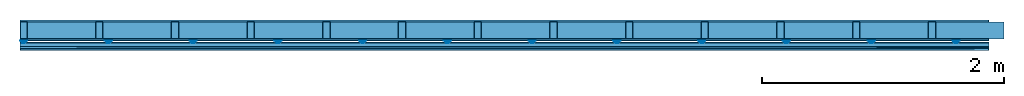
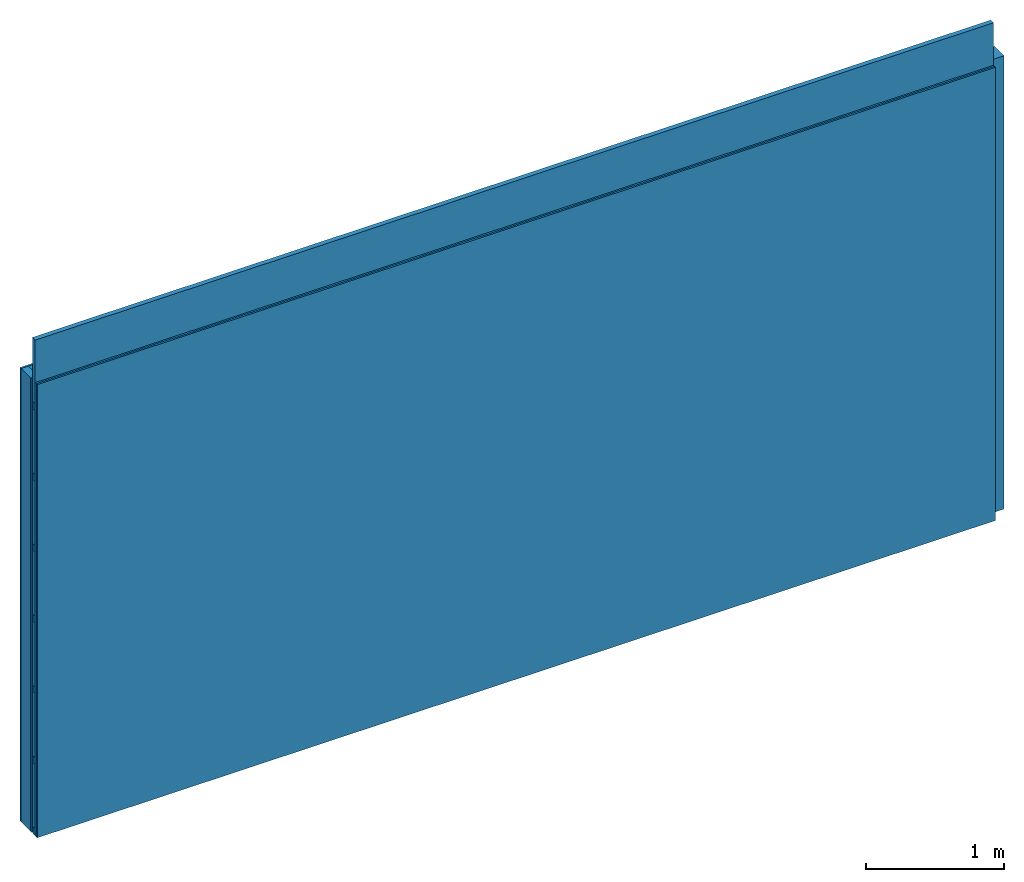
# One storey: 5 members, 4 plates, 1 element without a shape of its own.
"""IFC4 building model written with IfcOpenShell, lengths in metres."""

from ifc_helpers import new_model, si_unit, derived_unit, direction, frame, frame_2d, origin, origin_with_axes, place, context, project, spatial, polyline, rectangle, outline, extrude, material, layer, layer_set, type_object, element, aggregate, save


model = new_model("IFC4")

# Units and contexts
plan_context = context("Plan", 3, precision=1e-05, world=origin(), true_north=direction((0.0, 1.0)))
model_context = context("Model", 3, precision=1e-05, world=origin(), true_north=direction((0.0, 1.0)))
ifc_project = project(units=[si_unit("LENGTHUNIT", "METRE"), derived_unit("SOUNDPRESSUREUNIT", [(si_unit("PRESSUREUNIT", "PASCAL", prefix="MICRO"), 0)]), si_unit("ENERGYUNIT", "JOULE", prefix="MEGA"), si_unit("MASSUNIT", "GRAM", prefix="KILO"), derived_unit("THERMALTRANSMITTANCEUNIT", [(si_unit("POWERUNIT", "WATT"), 1), (si_unit("AREAUNIT", "SQUARE_METRE"), -1), (si_unit("THERMODYNAMICTEMPERATUREUNIT", "KELVIN"), -1)]), derived_unit("AREADENSITYUNIT", [(si_unit("MASSUNIT", "GRAM", prefix="KILO"), 1), (si_unit("AREAUNIT", "SQUARE_METRE"), -1)]), derived_unit("USERDEFINED", [(si_unit("ENERGYUNIT", "JOULE", prefix="MEGA"), 1), (si_unit("AREAUNIT", "SQUARE_METRE"), -1)])], contexts=[plan_context, model_context])

# Site, building, storey
site = spatial("IfcSite", under=ifc_project)
building_placement = place(None, origin())
building = spatial("IfcBuilding", under=site, at=building_placement)
storey_placement = place(building_placement, origin())
storey = spatial("IfcBuildingStorey", under=building, at=storey_placement)

# Wall, members, plates
ifc_material_1 = material(Name="Glued joints")
ifc_layer_1 = layer(ifc_material_1, 0.0, Name="Surface")
ifc_material_2 = material(Category="03.007")
ifc_layer_2 = layer(ifc_material_2, 0.015, Name="1st layer")
ifc_material_3 = material(Name="of the art")
ifc_layer_3 = layer(ifc_material_3, 0.0, Name="Bond")
ifc_layer_4 = layer(None, 0.14, Name="Support")
ifc_layer_5 = layer(ifc_material_3, 0.0, Name="Bond")
ifc_layer_6 = layer(ifc_material_2, 0.015, Name="1st layer")
ifc_layer_7 = layer(None, 0.02, Name="Coupling")
ifc_layer_8 = layer(None, 0.03, Name="Battens / profiles")
ifc_layer_9 = layer(ifc_material_2, 0.015, Name="Covering 1st layer")
ifc_layer_10 = layer(ifc_material_2, 0.015, Name="Covering 2nd layer")
ifc_layer_11 = layer(ifc_material_1, 0.0, Name="Surface")
ifc_layer_set = layer_set([ifc_layer_1, ifc_layer_2, ifc_layer_3, ifc_layer_4, ifc_layer_5, ifc_layer_6, ifc_layer_7, ifc_layer_8, ifc_layer_9, ifc_layer_10, ifc_layer_11])
wall_type = type_object("IfcWallType", Name="C0080", PredefinedType="NOTDEFINED", material=ifc_layer_set)
wall_placement = place(None, frame((0.0, 0.0, 0.0), z_axis=(0.0, -1.0, 0.0), x_axis=(1.0, 0.0, 0.0)))
wall = element("IfcWall", 1, at=wall_placement, inside=storey, type_object=wall_type, material=ifc_layer_set, Name="Wall #1")
ifc_material_4 = material()
member_1_placement = place(wall_placement, origin())
member_1 = element("IfcMember", 2, at=member_1_placement, material=ifc_material_4, Name="Support", context=plan_context, shape_type="SweptSolid", body=[
    extrude(rectangle(XDim=0.06, YDim=0.14, at=frame_2d((0.03, 0.07), x_axis=(1.0, 0.0))), frame((0.0, 4.0, 0.015), z_axis=(0.0, -1.0, 0.0), x_axis=(1.0, 0.0, 0.0)), (0.0, 0.0, 1.0), 4.0),
    extrude(rectangle(XDim=0.06, YDim=0.14, at=frame_2d((0.03, 0.07), x_axis=(1.0, 0.0))), frame((0.625, 4.0, 0.015), z_axis=(0.0, -1.0, 0.0), x_axis=(1.0, 0.0, 0.0)), (0.0, 0.0, 1.0), 4.0),
    extrude(rectangle(XDim=0.06, YDim=0.14, at=frame_2d((0.03, 0.07), x_axis=(1.0, 0.0))), frame((1.25, 4.0, 0.015), z_axis=(0.0, -1.0, 0.0), x_axis=(1.0, 0.0, 0.0)), (0.0, 0.0, 1.0), 4.0),
    extrude(rectangle(XDim=0.06, YDim=0.14, at=frame_2d((0.03, 0.07), x_axis=(1.0, 0.0))), frame((1.875, 4.0, 0.015), z_axis=(0.0, -1.0, 0.0), x_axis=(1.0, 0.0, 0.0)), (0.0, 0.0, 1.0), 4.0),
    extrude(rectangle(XDim=0.06, YDim=0.14, at=frame_2d((0.03, 0.07), x_axis=(1.0, 0.0))), frame((2.5, 4.0, 0.015), z_axis=(0.0, -1.0, 0.0), x_axis=(1.0, 0.0, 0.0)), (0.0, 0.0, 1.0), 4.0),
    extrude(rectangle(XDim=0.06, YDim=0.14, at=frame_2d((0.03, 0.07), x_axis=(1.0, 0.0))), frame((3.125, 4.0, 0.015), z_axis=(0.0, -1.0, 0.0), x_axis=(1.0, 0.0, 0.0)), (0.0, 0.0, 1.0), 4.0),
    extrude(rectangle(XDim=0.06, YDim=0.14, at=frame_2d((0.03, 0.07), x_axis=(1.0, 0.0))), frame((3.75, 4.0, 0.015), z_axis=(0.0, -1.0, 0.0), x_axis=(1.0, 0.0, 0.0)), (0.0, 0.0, 1.0), 4.0),
    extrude(rectangle(XDim=0.06, YDim=0.14, at=frame_2d((0.03, 0.07), x_axis=(1.0, 0.0))), frame((4.375, 4.0, 0.015), z_axis=(0.0, -1.0, 0.0), x_axis=(1.0, 0.0, 0.0)), (0.0, 0.0, 1.0), 4.0),
    extrude(rectangle(XDim=0.06, YDim=0.14, at=frame_2d((0.03, 0.07), x_axis=(1.0, 0.0))), frame((5.0, 4.0, 0.015), z_axis=(0.0, -1.0, 0.0), x_axis=(1.0, 0.0, 0.0)), (0.0, 0.0, 1.0), 4.0),
    extrude(rectangle(XDim=0.06, YDim=0.14, at=frame_2d((0.03, 0.07), x_axis=(1.0, 0.0))), frame((5.625, 4.0, 0.015), z_axis=(0.0, -1.0, 0.0), x_axis=(1.0, 0.0, 0.0)), (0.0, 0.0, 1.0), 4.0),
    extrude(rectangle(XDim=0.06, YDim=0.14, at=frame_2d((0.03, 0.07), x_axis=(1.0, 0.0))), frame((6.25, 4.0, 0.015), z_axis=(0.0, -1.0, 0.0), x_axis=(1.0, 0.0, 0.0)), (0.0, 0.0, 1.0), 4.0),
    extrude(rectangle(XDim=0.06, YDim=0.14, at=frame_2d((0.03, 0.07), x_axis=(1.0, 0.0))), frame((6.875, 4.0, 0.015), z_axis=(0.0, -1.0, 0.0), x_axis=(1.0, 0.0, 0.0)), (0.0, 0.0, 1.0), 4.0),
    extrude(rectangle(XDim=0.06, YDim=0.14, at=frame_2d((0.03, 0.07), x_axis=(1.0, 0.0))), frame((7.5, 4.0, 0.015), z_axis=(0.0, -1.0, 0.0), x_axis=(1.0, 0.0, 0.0)), (0.0, 0.0, 1.0), 4.0),
])
ifc_material_5 = material()
member_2_placement = place(wall_placement, origin())
member_2 = element("IfcMember", 3, at=member_2_placement, material=ifc_material_5, Name="Cavity", context=plan_context, shape_type="SweptSolid", body=[
    extrude(rectangle(XDim=0.565, YDim=0.14, at=frame_2d((0.2825, 0.07), x_axis=(1.0, 0.0))), frame((0.06, 4.0, 0.015), z_axis=(0.0, -1.0, 0.0), x_axis=(1.0, 0.0, 0.0)), (0.0, 0.0, 1.0), 4.0),
    extrude(rectangle(XDim=0.565, YDim=0.14, at=frame_2d((0.2825, 0.07), x_axis=(1.0, 0.0))), frame((0.685, 4.0, 0.015), z_axis=(0.0, -1.0, 0.0), x_axis=(1.0, 0.0, 0.0)), (0.0, 0.0, 1.0), 4.0),
    extrude(rectangle(XDim=0.565, YDim=0.14, at=frame_2d((0.2825, 0.07), x_axis=(1.0, 0.0))), frame((1.31, 4.0, 0.015), z_axis=(0.0, -1.0, 0.0), x_axis=(1.0, 0.0, 0.0)), (0.0, 0.0, 1.0), 4.0),
    extrude(rectangle(XDim=0.565, YDim=0.14, at=frame_2d((0.2825, 0.07), x_axis=(1.0, 0.0))), frame((1.935, 4.0, 0.015), z_axis=(0.0, -1.0, 0.0), x_axis=(1.0, 0.0, 0.0)), (0.0, 0.0, 1.0), 4.0),
    extrude(rectangle(XDim=0.565, YDim=0.14, at=frame_2d((0.2825, 0.07), x_axis=(1.0, 0.0))), frame((2.56, 4.0, 0.015), z_axis=(0.0, -1.0, 0.0), x_axis=(1.0, 0.0, 0.0)), (0.0, 0.0, 1.0), 4.0),
    extrude(rectangle(XDim=0.565, YDim=0.14, at=frame_2d((0.2825, 0.07), x_axis=(1.0, 0.0))), frame((3.185, 4.0, 0.015), z_axis=(0.0, -1.0, 0.0), x_axis=(1.0, 0.0, 0.0)), (0.0, 0.0, 1.0), 4.0),
    extrude(rectangle(XDim=0.565, YDim=0.14, at=frame_2d((0.2825, 0.07), x_axis=(1.0, 0.0))), frame((3.81, 4.0, 0.015), z_axis=(0.0, -1.0, 0.0), x_axis=(1.0, 0.0, 0.0)), (0.0, 0.0, 1.0), 4.0),
    extrude(rectangle(XDim=0.565, YDim=0.14, at=frame_2d((0.2825, 0.07), x_axis=(1.0, 0.0))), frame((4.435, 4.0, 0.015), z_axis=(0.0, -1.0, 0.0), x_axis=(1.0, 0.0, 0.0)), (0.0, 0.0, 1.0), 4.0),
    extrude(rectangle(XDim=0.565, YDim=0.14, at=frame_2d((0.2825, 0.07), x_axis=(1.0, 0.0))), frame((5.06, 4.0, 0.015), z_axis=(0.0, -1.0, 0.0), x_axis=(1.0, 0.0, 0.0)), (0.0, 0.0, 1.0), 4.0),
    extrude(rectangle(XDim=0.565, YDim=0.14, at=frame_2d((0.2825, 0.07), x_axis=(1.0, 0.0))), frame((5.685, 4.0, 0.015), z_axis=(0.0, -1.0, 0.0), x_axis=(1.0, 0.0, 0.0)), (0.0, 0.0, 1.0), 4.0),
    extrude(rectangle(XDim=0.565, YDim=0.14, at=frame_2d((0.2825, 0.07), x_axis=(1.0, 0.0))), frame((6.31, 4.0, 0.015), z_axis=(0.0, -1.0, 0.0), x_axis=(1.0, 0.0, 0.0)), (0.0, 0.0, 1.0), 4.0),
    extrude(rectangle(XDim=0.565, YDim=0.14, at=frame_2d((0.2825, 0.07), x_axis=(1.0, 0.0))), frame((6.935, 4.0, 0.015), z_axis=(0.0, -1.0, 0.0), x_axis=(1.0, 0.0, 0.0)), (0.0, 0.0, 1.0), 4.0),
    extrude(rectangle(XDim=0.565, YDim=0.14, at=frame_2d((0.2825, 0.07), x_axis=(1.0, 0.0))), frame((7.56, 4.0, 0.015), z_axis=(0.0, -1.0, 0.0), x_axis=(1.0, 0.0, 0.0)), (0.0, 0.0, 1.0), 4.0),
])
ifc_material_6 = material()
member_3_placement = place(wall_placement, origin())
member_3 = element("IfcMember", 4, at=member_3_placement, material=ifc_material_6, Name="Coupling", context=plan_context, shape_type="SweptSolid", body=[
    extrude(outline(polyline([(0.0, 0.0), (0.06, 0.0), (0.04, 0.02), (0.02, 0.02), (0.0, 0.0)])), frame((0.0, 4.0, 0.17), z_axis=(0.0, -1.0, 0.0), x_axis=(1.0, 0.0, 0.0)), (0.0, 0.0, 1.0), 4.0),
    extrude(outline(polyline([(0.0, 0.0), (0.06, 0.0), (0.04, 0.02), (0.02, 0.02), (0.0, 0.0)])), frame((0.7, 4.0, 0.17), z_axis=(0.0, -1.0, 0.0), x_axis=(1.0, 0.0, 0.0)), (0.0, 0.0, 1.0), 4.0),
    extrude(outline(polyline([(0.0, 0.0), (0.06, 0.0), (0.04, 0.02), (0.02, 0.02), (0.0, 0.0)])), frame((1.4, 4.0, 0.17), z_axis=(0.0, -1.0, 0.0), x_axis=(1.0, 0.0, 0.0)), (0.0, 0.0, 1.0), 4.0),
    extrude(outline(polyline([(0.0, 0.0), (0.06, 0.0), (0.04, 0.02), (0.02, 0.02), (0.0, 0.0)])), frame((2.1, 4.0, 0.17), z_axis=(0.0, -1.0, 0.0), x_axis=(1.0, 0.0, 0.0)), (0.0, 0.0, 1.0), 4.0),
    extrude(outline(polyline([(0.0, 0.0), (0.06, 0.0), (0.04, 0.02), (0.02, 0.02), (0.0, 0.0)])), frame((2.8, 4.0, 0.17), z_axis=(0.0, -1.0, 0.0), x_axis=(1.0, 0.0, 0.0)), (0.0, 0.0, 1.0), 4.0),
    extrude(outline(polyline([(0.0, 0.0), (0.06, 0.0), (0.04, 0.02), (0.02, 0.02), (0.0, 0.0)])), frame((3.5, 4.0, 0.17), z_axis=(0.0, -1.0, 0.0), x_axis=(1.0, 0.0, 0.0)), (0.0, 0.0, 1.0), 4.0),
    extrude(outline(polyline([(0.0, 0.0), (0.06, 0.0), (0.04, 0.02), (0.02, 0.02), (0.0, 0.0)])), frame((4.2, 4.0, 0.17), z_axis=(0.0, -1.0, 0.0), x_axis=(1.0, 0.0, 0.0)), (0.0, 0.0, 1.0), 4.0),
    extrude(outline(polyline([(0.0, 0.0), (0.06, 0.0), (0.04, 0.02), (0.02, 0.02), (0.0, 0.0)])), frame((4.9, 4.0, 0.17), z_axis=(0.0, -1.0, 0.0), x_axis=(1.0, 0.0, 0.0)), (0.0, 0.0, 1.0), 4.0),
    extrude(outline(polyline([(0.0, 0.0), (0.06, 0.0), (0.04, 0.02), (0.02, 0.02), (0.0, 0.0)])), frame((5.6, 4.0, 0.17), z_axis=(0.0, -1.0, 0.0), x_axis=(1.0, 0.0, 0.0)), (0.0, 0.0, 1.0), 4.0),
    extrude(outline(polyline([(0.0, 0.0), (0.06, 0.0), (0.04, 0.02), (0.02, 0.02), (0.0, 0.0)])), frame((6.3, 4.0, 0.17), z_axis=(0.0, -1.0, 0.0), x_axis=(1.0, 0.0, 0.0)), (0.0, 0.0, 1.0), 4.0),
    extrude(outline(polyline([(0.0, 0.0), (0.06, 0.0), (0.04, 0.02), (0.02, 0.02), (0.0, 0.0)])), frame((7.0, 4.0, 0.17), z_axis=(0.0, -1.0, 0.0), x_axis=(1.0, 0.0, 0.0)), (0.0, 0.0, 1.0), 4.0),
    extrude(outline(polyline([(0.0, 0.0), (0.06, 0.0), (0.04, 0.02), (0.02, 0.02), (0.0, 0.0)])), frame((7.7, 4.0, 0.17), z_axis=(0.0, -1.0, 0.0), x_axis=(1.0, 0.0, 0.0)), (0.0, 0.0, 1.0), 4.0),
])
member_4_placement = place(wall_placement, origin())
member_4 = element("IfcMember", 5, at=member_4_placement, material=ifc_material_6, Name="Battens / profiles", context=plan_context, shape_type="SweptSolid", body=[
    extrude(rectangle(XDim=0.06, YDim=0.03, at=frame_2d((0.03, 0.015), x_axis=(1.0, 0.0))), frame((0.0, 0.0, 0.19), z_axis=(1.0, 0.0, 0.0), x_axis=(0.0, 1.0, 0.0)), (0.0, 0.0, 1.0), 8.0),
    extrude(rectangle(XDim=0.06, YDim=0.03, at=frame_2d((0.03, 0.015), x_axis=(1.0, 0.0))), frame((0.0, 0.625, 0.19), z_axis=(1.0, 0.0, 0.0), x_axis=(0.0, 1.0, 0.0)), (0.0, 0.0, 1.0), 8.0),
    extrude(rectangle(XDim=0.06, YDim=0.03, at=frame_2d((0.03, 0.015), x_axis=(1.0, 0.0))), frame((0.0, 1.25, 0.19), z_axis=(1.0, 0.0, 0.0), x_axis=(0.0, 1.0, 0.0)), (0.0, 0.0, 1.0), 8.0),
    extrude(rectangle(XDim=0.06, YDim=0.03, at=frame_2d((0.03, 0.015), x_axis=(1.0, 0.0))), frame((0.0, 1.875, 0.19), z_axis=(1.0, 0.0, 0.0), x_axis=(0.0, 1.0, 0.0)), (0.0, 0.0, 1.0), 8.0),
    extrude(rectangle(XDim=0.06, YDim=0.03, at=frame_2d((0.03, 0.015), x_axis=(1.0, 0.0))), frame((0.0, 2.5, 0.19), z_axis=(1.0, 0.0, 0.0), x_axis=(0.0, 1.0, 0.0)), (0.0, 0.0, 1.0), 8.0),
    extrude(rectangle(XDim=0.06, YDim=0.03, at=frame_2d((0.03, 0.015), x_axis=(1.0, 0.0))), frame((0.0, 3.125, 0.19), z_axis=(1.0, 0.0, 0.0), x_axis=(0.0, 1.0, 0.0)), (0.0, 0.0, 1.0), 8.0),
    extrude(rectangle(XDim=0.06, YDim=0.03, at=frame_2d((0.03, 0.015), x_axis=(1.0, 0.0))), frame((0.0, 3.75, 0.19), z_axis=(1.0, 0.0, 0.0), x_axis=(0.0, 1.0, 0.0)), (0.0, 0.0, 1.0), 8.0),
])
member_5_placement = place(wall_placement, origin())
member_5 = element("IfcMember", 6, at=member_5_placement, material=ifc_material_5, Name="Cavity", context=plan_context, shape_type="SweptSolid", body=[
    extrude(rectangle(XDim=0.565, YDim=0.04, at=frame_2d((0.2825, 0.02), x_axis=(1.0, 0.0))), frame((0.0, 0.06, 0.18), z_axis=(1.0, 0.0, 0.0), x_axis=(0.0, 1.0, 0.0)), (0.0, 0.0, 1.0), 8.0),
    extrude(rectangle(XDim=0.565, YDim=0.04, at=frame_2d((0.2825, 0.02), x_axis=(1.0, 0.0))), frame((0.0, 0.685, 0.18), z_axis=(1.0, 0.0, 0.0), x_axis=(0.0, 1.0, 0.0)), (0.0, 0.0, 1.0), 8.0),
    extrude(rectangle(XDim=0.565, YDim=0.04, at=frame_2d((0.2825, 0.02), x_axis=(1.0, 0.0))), frame((0.0, 1.31, 0.18), z_axis=(1.0, 0.0, 0.0), x_axis=(0.0, 1.0, 0.0)), (0.0, 0.0, 1.0), 8.0),
    extrude(rectangle(XDim=0.565, YDim=0.04, at=frame_2d((0.2825, 0.02), x_axis=(1.0, 0.0))), frame((0.0, 1.935, 0.18), z_axis=(1.0, 0.0, 0.0), x_axis=(0.0, 1.0, 0.0)), (0.0, 0.0, 1.0), 8.0),
    extrude(rectangle(XDim=0.565, YDim=0.04, at=frame_2d((0.2825, 0.02), x_axis=(1.0, 0.0))), frame((0.0, 2.56, 0.18), z_axis=(1.0, 0.0, 0.0), x_axis=(0.0, 1.0, 0.0)), (0.0, 0.0, 1.0), 8.0),
    extrude(rectangle(XDim=0.565, YDim=0.04, at=frame_2d((0.2825, 0.02), x_axis=(1.0, 0.0))), frame((0.0, 3.185, 0.18), z_axis=(1.0, 0.0, 0.0), x_axis=(0.0, 1.0, 0.0)), (0.0, 0.0, 1.0), 8.0),
    extrude(rectangle(XDim=0.565, YDim=0.04, at=frame_2d((0.2825, 0.02), x_axis=(1.0, 0.0))), frame((0.0, 3.81, 0.18), z_axis=(1.0, 0.0, 0.0), x_axis=(0.0, 1.0, 0.0)), (0.0, 0.0, 1.0), 8.0),
])
plate_1_placement = place(wall_placement, origin())
plate_1 = element("IfcPlate", 7, at=plate_1_placement, material=ifc_material_2, Name="1st layer", context=plan_context, shape_type="SweptSolid", body=[
    extrude(rectangle(XDim=8.0, YDim=4.0, at=frame_2d((4.0, 2.0), x_axis=(1.0, 0.0))), origin_with_axes(), (0.0, 0.0, 1.0), 0.015),
])
plate_2_placement = place(wall_placement, origin())
plate_2 = element("IfcPlate", 8, at=plate_2_placement, material=ifc_material_2, Name="1st layer", context=plan_context, shape_type="SweptSolid", body=[
    extrude(rectangle(XDim=8.0, YDim=4.0, at=frame_2d((4.0, 2.0), x_axis=(1.0, 0.0))), frame((0.0, 0.0, 0.155), z_axis=(0.0, 0.0, 1.0), x_axis=(1.0, 0.0, 0.0)), (0.0, 0.0, 1.0), 0.015),
])
plate_3_placement = place(wall_placement, origin())
plate_3 = element("IfcPlate", 9, at=plate_3_placement, material=ifc_material_2, Name="Covering 1st layer", context=plan_context, shape_type="SweptSolid", body=[
    extrude(rectangle(XDim=8.0, YDim=4.0, at=frame_2d((4.0, 2.0), x_axis=(1.0, 0.0))), frame((0.0, 0.0, 0.22), z_axis=(0.0, 0.0, 1.0), x_axis=(1.0, 0.0, 0.0)), (0.0, 0.0, 1.0), 0.015),
])
plate_4_placement = place(wall_placement, origin())
plate_4 = element("IfcPlate", 10, at=plate_4_placement, material=ifc_material_2, Name="Covering 2nd layer", context=plan_context, shape_type="SweptSolid", body=[
    extrude(rectangle(XDim=8.0, YDim=4.0, at=frame_2d((4.0, 2.0), x_axis=(1.0, 0.0))), frame((0.0, 0.0, 0.235), z_axis=(0.0, 0.0, 1.0), x_axis=(1.0, 0.0, 0.0)), (0.0, 0.0, 1.0), 0.015),
])
aggregate(wall, [plate_1, member_1, member_2, plate_2, member_3, member_4, member_5, plate_3, plate_4])

save(model, "model.ifc")
